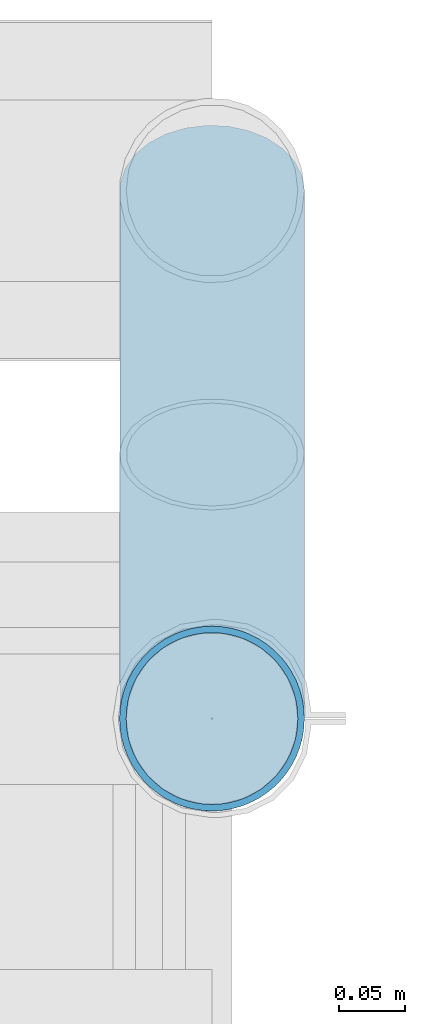
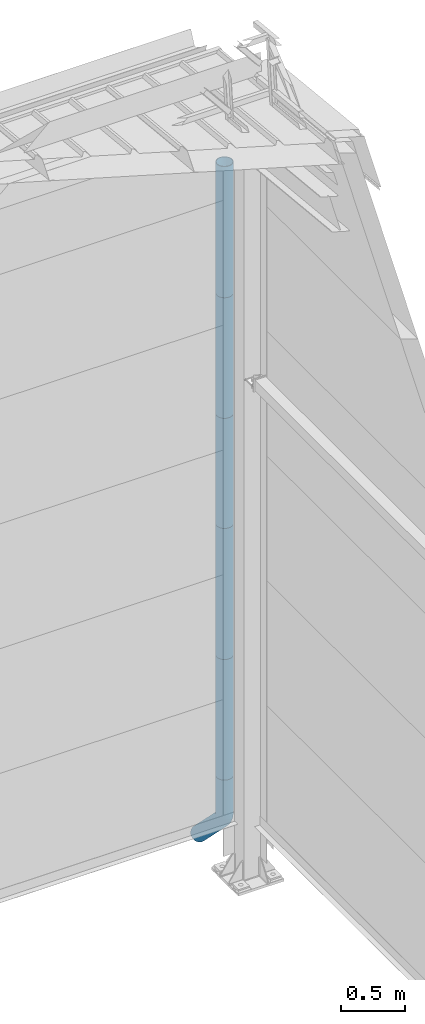
# One storey, part 81 of 709: 6 beams, 6 elements without a shape of their own.
"""IFC4 building model written with IfcOpenShell, lengths in millimetres."""

from ifc_helpers import new_model, entity, si_unit, direction, frame, origin_with_axes, place, context, subcontext, project, spatial, line, indexed_curve, outline, extrude, material, element, aggregate, save


model = new_model("IFC4")

# Units and contexts
model_context = context("Model", 3, precision=0.2, world=origin_with_axes(), true_north=direction((0.0, 1.0)))
body_context = subcontext(model_context, "Body", "Model", "MODEL_VIEW")
ifc_project = project(units=[si_unit("LENGTHUNIT", "METRE", prefix="MILLI"), si_unit("AREAUNIT", "SQUARE_METRE"), si_unit("VOLUMEUNIT", "CUBIC_METRE"), si_unit("MASSUNIT", "GRAM", prefix="KILO"), si_unit("TIMEUNIT", "SECOND"), si_unit("PLANEANGLEUNIT", "RADIAN"), si_unit("SOLIDANGLEUNIT", "STERADIAN"), si_unit("THERMODYNAMICTEMPERATUREUNIT", "DEGREE_CELSIUS"), si_unit("LUMINOUSINTENSITYUNIT", "LUMEN")], contexts=[model_context])

# Site, building, storey
site_placement = place(None, origin_with_axes())
site = spatial("IfcSite", under=ifc_project, at=site_placement, CompositionType="ELEMENT")
building_placement = place(site_placement, origin_with_axes())
building = spatial("IfcBuilding", under=site, at=building_placement, Name="Undefined", CompositionType="ELEMENT")
storey_placement = place(building_placement, origin_with_axes())
storey = spatial("IfcBuildingStorey", under=building, at=storey_placement, Name="Undefined", CompositionType="ELEMENT", Elevation=0.0)

# Assembly, beam
assembly_1_placement = place(storey_placement, frame((50000.0, 22420.0, 6276.92297), z_axis=(0.0, -1.0, 0.0), x_axis=(0.0, 0.0, -1.0)))
assembly_1 = element("IfcElementAssembly", 1, at=assembly_1_placement, inside=storey)
ifc_material = material(Name="Steel_Undefined", Category="STEEL")
beam_1_placement = place(assembly_1_placement, origin_with_axes())
beam_1 = element("IfcBeam", 2, at=beam_1_placement, material=ifc_material, ObjectType="614", context=body_context, shape_type="SolidModel", body=[
    extrude(outline(indexed_curve([(70.0, 0.0), (69.61653, 7.31699), (68.47033, 14.55382), (66.57396, 21.63119), (63.94818, 28.47157), (60.62178, 35.0), (56.63119, 41.14497), (52.02014, 46.83914), (46.83914, 52.02014), (41.14497, 56.63119), (35.0, 60.62178), (28.47157, 63.94818), (21.63119, 66.57396), (14.55382, 68.47033), (7.31699, 69.61653), (0.0, 70.0), (-7.31699, 69.61653), (-14.55382, 68.47033), (-21.63119, 66.57396), (-28.47157, 63.94818), (-35.0, 60.62178), (-41.14497, 56.63119), (-46.83914, 52.02014), (-52.02014, 46.83914), (-56.63119, 41.14497), (-60.62178, 35.0), (-63.94818, 28.47157), (-66.57396, 21.63119), (-68.47033, 14.55382), (-69.61653, 7.31699), (-70.0, 0.0), (-69.61653, -7.31699), (-68.47033, -14.55382), (-66.57396, -21.63119), (-63.94818, -28.47157), (-60.62178, -35.0), (-56.63119, -41.14497), (-52.02014, -46.83914), (-46.83914, -52.02014), (-41.14497, -56.63119), (-35.0, -60.62178), (-28.47157, -63.94818), (-21.63119, -66.57396), (-14.55382, -68.47033), (-7.31699, -69.61653), (0.0, -70.0), (7.31699, -69.61653), (14.55382, -68.47033), (21.63119, -66.57396), (28.47157, -63.94818), (35.0, -60.62178), (41.14497, -56.63119), (46.83914, -52.02014), (52.02014, -46.83914), (56.63119, -41.14497), (60.62178, -35.0), (63.94818, -28.47157), (66.57396, -21.63119), (68.47033, -14.55382), (69.61653, -7.31699)], segments=[line(1, 2, 3, 4, 5, 6, 7, 8, 9, 10, 11, 12, 13, 14, 15, 16, 17, 18, 19, 20, 21, 22, 23, 24, 25, 26, 27, 28, 29, 30, 31, 32, 33, 34, 35, 36, 37, 38, 39, 40, 41, 42, 43, 44, 45, 46, 47, 48, 49, 50, 51, 52, 53, 54, 55, 56, 57, 58, 59, 60, 1)]), holes=[indexed_curve([(65.0, 0.0), (64.64392, -6.79435), (63.57959, -13.51426), (61.81867, -20.0861), (59.38045, -26.43788), (56.29165, -32.5), (52.5861, -38.20604), (48.30441, -43.49349), (43.49349, -48.30441), (38.20604, -52.5861), (32.5, -56.29165), (26.43788, -59.38045), (20.0861, -61.81867), (13.51426, -63.57959), (6.79435, -64.64392), (0.0, -65.0), (-6.79435, -64.64392), (-13.51426, -63.57959), (-20.0861, -61.81867), (-26.43788, -59.38045), (-32.5, -56.29165), (-38.20604, -52.5861), (-43.49349, -48.30441), (-48.30441, -43.49349), (-52.5861, -38.20604), (-56.29165, -32.5), (-59.38045, -26.43788), (-61.81867, -20.0861), (-63.57959, -13.51426), (-64.64392, -6.79435), (-65.0, 0.0), (-64.64392, 6.79435), (-63.57959, 13.51426), (-61.81867, 20.0861), (-59.38045, 26.43788), (-56.29165, 32.5), (-52.5861, 38.20604), (-48.30441, 43.49349), (-43.49349, 48.30441), (-38.20604, 52.5861), (-32.5, 56.29165), (-26.43788, 59.38045), (-20.0861, 61.81867), (-13.51426, 63.57959), (-6.79435, 64.64392), (0.0, 65.0), (6.79435, 64.64392), (13.51426, 63.57959), (20.0861, 61.81867), (26.43788, 59.38045), (32.5, 56.29165), (38.20604, 52.5861), (43.49349, 48.30441), (48.30441, 43.49349), (52.5861, 38.20604), (56.29165, 32.5), (59.38045, 26.43788), (61.81867, 20.0861), (63.57959, 13.51426), (64.64392, 6.79435)], segments=[line(1, 2, 3, 4, 5, 6, 7, 8, 9, 10, 11, 12, 13, 14, 15, 16, 17, 18, 19, 20, 21, 22, 23, 24, 25, 26, 27, 28, 29, 30, 31, 32, 33, 34, 35, 36, 37, 38, 39, 40, 41, 42, 43, 44, 45, 46, 47, 48, 49, 50, 51, 52, 53, 54, 55, 56, 57, 58, 59, 60, 1)])]), frame((0.0, 0.0, 0.0), z_axis=(-1.0, 0.0, 0.0), x_axis=(0.0, 0.0, 1.0)), (0.0, 0.0, -1.0), 1250.0),
])
aggregate(assembly_1, [beam_1])

assembly_2_placement = place(storey_placement, frame((50000.0, 22420.0, 5126.92297), z_axis=(0.0, -1.0, 0.0), x_axis=(0.0, 0.0, -1.0)))
assembly_2 = element("IfcElementAssembly", 3, at=assembly_2_placement, inside=storey)
beam_2_placement = place(assembly_2_placement, origin_with_axes())
beam_2 = element("IfcBeam", 4, at=beam_2_placement, material=ifc_material, ObjectType="614", context=body_context, shape_type="SolidModel", body=[
    extrude(outline(indexed_curve([(70.0, 0.0), (69.61653, 7.31699), (68.47033, 14.55382), (66.57396, 21.63119), (63.94818, 28.47157), (60.62178, 35.0), (56.63119, 41.14497), (52.02014, 46.83914), (46.83914, 52.02014), (41.14497, 56.63119), (35.0, 60.62178), (28.47157, 63.94818), (21.63119, 66.57396), (14.55382, 68.47033), (7.31699, 69.61653), (0.0, 70.0), (-7.31699, 69.61653), (-14.55382, 68.47033), (-21.63119, 66.57396), (-28.47157, 63.94818), (-35.0, 60.62178), (-41.14497, 56.63119), (-46.83914, 52.02014), (-52.02014, 46.83914), (-56.63119, 41.14497), (-60.62178, 35.0), (-63.94818, 28.47157), (-66.57396, 21.63119), (-68.47033, 14.55382), (-69.61653, 7.31699), (-70.0, 0.0), (-69.61653, -7.31699), (-68.47033, -14.55382), (-66.57396, -21.63119), (-63.94818, -28.47157), (-60.62178, -35.0), (-56.63119, -41.14497), (-52.02014, -46.83914), (-46.83914, -52.02014), (-41.14497, -56.63119), (-35.0, -60.62178), (-28.47157, -63.94818), (-21.63119, -66.57396), (-14.55382, -68.47033), (-7.31699, -69.61653), (0.0, -70.0), (7.31699, -69.61653), (14.55382, -68.47033), (21.63119, -66.57396), (28.47157, -63.94818), (35.0, -60.62178), (41.14497, -56.63119), (46.83914, -52.02014), (52.02014, -46.83914), (56.63119, -41.14497), (60.62178, -35.0), (63.94818, -28.47157), (66.57396, -21.63119), (68.47033, -14.55382), (69.61653, -7.31699)], segments=[line(1, 2, 3, 4, 5, 6, 7, 8, 9, 10, 11, 12, 13, 14, 15, 16, 17, 18, 19, 20, 21, 22, 23, 24, 25, 26, 27, 28, 29, 30, 31, 32, 33, 34, 35, 36, 37, 38, 39, 40, 41, 42, 43, 44, 45, 46, 47, 48, 49, 50, 51, 52, 53, 54, 55, 56, 57, 58, 59, 60, 1)]), holes=[indexed_curve([(65.0, 0.0), (64.64392, -6.79435), (63.57959, -13.51426), (61.81867, -20.0861), (59.38045, -26.43788), (56.29165, -32.5), (52.5861, -38.20604), (48.30441, -43.49349), (43.49349, -48.30441), (38.20604, -52.5861), (32.5, -56.29165), (26.43788, -59.38045), (20.0861, -61.81867), (13.51426, -63.57959), (6.79435, -64.64392), (0.0, -65.0), (-6.79435, -64.64392), (-13.51426, -63.57959), (-20.0861, -61.81867), (-26.43788, -59.38045), (-32.5, -56.29165), (-38.20604, -52.5861), (-43.49349, -48.30441), (-48.30441, -43.49349), (-52.5861, -38.20604), (-56.29165, -32.5), (-59.38045, -26.43788), (-61.81867, -20.0861), (-63.57959, -13.51426), (-64.64392, -6.79435), (-65.0, 0.0), (-64.64392, 6.79435), (-63.57959, 13.51426), (-61.81867, 20.0861), (-59.38045, 26.43788), (-56.29165, 32.5), (-52.5861, 38.20604), (-48.30441, 43.49349), (-43.49349, 48.30441), (-38.20604, 52.5861), (-32.5, 56.29165), (-26.43788, 59.38045), (-20.0861, 61.81867), (-13.51426, 63.57959), (-6.79435, 64.64392), (0.0, 65.0), (6.79435, 64.64392), (13.51426, 63.57959), (20.0861, 61.81867), (26.43788, 59.38045), (32.5, 56.29165), (38.20604, 52.5861), (43.49349, 48.30441), (48.30441, 43.49349), (52.5861, 38.20604), (56.29165, 32.5), (59.38045, 26.43788), (61.81867, 20.0861), (63.57959, 13.51426), (64.64392, 6.79435)], segments=[line(1, 2, 3, 4, 5, 6, 7, 8, 9, 10, 11, 12, 13, 14, 15, 16, 17, 18, 19, 20, 21, 22, 23, 24, 25, 26, 27, 28, 29, 30, 31, 32, 33, 34, 35, 36, 37, 38, 39, 40, 41, 42, 43, 44, 45, 46, 47, 48, 49, 50, 51, 52, 53, 54, 55, 56, 57, 58, 59, 60, 1)])]), frame((0.0, 0.0, 0.0), z_axis=(-1.0, 0.0, 0.0), x_axis=(0.0, 0.0, 1.0)), (0.0, 0.0, -1.0), 1250.0),
])
aggregate(assembly_2, [beam_2])

assembly_3_placement = place(storey_placement, frame((50000.0, 22420.0, 3976.92297), z_axis=(0.0, -1.0, 0.0), x_axis=(0.0, 0.0, -1.0)))
assembly_3 = element("IfcElementAssembly", 5, at=assembly_3_placement, inside=storey)
beam_3_placement = place(assembly_3_placement, origin_with_axes())
beam_3 = element("IfcBeam", 6, at=beam_3_placement, material=ifc_material, ObjectType="614", context=body_context, shape_type="SolidModel", body=[
    extrude(outline(indexed_curve([(70.0, 0.0), (69.61653, 7.31699), (68.47033, 14.55382), (66.57396, 21.63119), (63.94818, 28.47157), (60.62178, 35.0), (56.63119, 41.14497), (52.02014, 46.83914), (46.83914, 52.02014), (41.14497, 56.63119), (35.0, 60.62178), (28.47157, 63.94818), (21.63119, 66.57396), (14.55382, 68.47033), (7.31699, 69.61653), (0.0, 70.0), (-7.31699, 69.61653), (-14.55382, 68.47033), (-21.63119, 66.57396), (-28.47157, 63.94818), (-35.0, 60.62178), (-41.14497, 56.63119), (-46.83914, 52.02014), (-52.02014, 46.83914), (-56.63119, 41.14497), (-60.62178, 35.0), (-63.94818, 28.47157), (-66.57396, 21.63119), (-68.47033, 14.55382), (-69.61653, 7.31699), (-70.0, 0.0), (-69.61653, -7.31699), (-68.47033, -14.55382), (-66.57396, -21.63119), (-63.94818, -28.47157), (-60.62178, -35.0), (-56.63119, -41.14497), (-52.02014, -46.83914), (-46.83914, -52.02014), (-41.14497, -56.63119), (-35.0, -60.62178), (-28.47157, -63.94818), (-21.63119, -66.57396), (-14.55382, -68.47033), (-7.31699, -69.61653), (0.0, -70.0), (7.31699, -69.61653), (14.55382, -68.47033), (21.63119, -66.57396), (28.47157, -63.94818), (35.0, -60.62178), (41.14497, -56.63119), (46.83914, -52.02014), (52.02014, -46.83914), (56.63119, -41.14497), (60.62178, -35.0), (63.94818, -28.47157), (66.57396, -21.63119), (68.47033, -14.55382), (69.61653, -7.31699)], segments=[line(1, 2, 3, 4, 5, 6, 7, 8, 9, 10, 11, 12, 13, 14, 15, 16, 17, 18, 19, 20, 21, 22, 23, 24, 25, 26, 27, 28, 29, 30, 31, 32, 33, 34, 35, 36, 37, 38, 39, 40, 41, 42, 43, 44, 45, 46, 47, 48, 49, 50, 51, 52, 53, 54, 55, 56, 57, 58, 59, 60, 1)]), holes=[indexed_curve([(65.0, 0.0), (64.64392, -6.79435), (63.57959, -13.51426), (61.81867, -20.0861), (59.38045, -26.43788), (56.29165, -32.5), (52.5861, -38.20604), (48.30441, -43.49349), (43.49349, -48.30441), (38.20604, -52.5861), (32.5, -56.29165), (26.43788, -59.38045), (20.0861, -61.81867), (13.51426, -63.57959), (6.79435, -64.64392), (0.0, -65.0), (-6.79435, -64.64392), (-13.51426, -63.57959), (-20.0861, -61.81867), (-26.43788, -59.38045), (-32.5, -56.29165), (-38.20604, -52.5861), (-43.49349, -48.30441), (-48.30441, -43.49349), (-52.5861, -38.20604), (-56.29165, -32.5), (-59.38045, -26.43788), (-61.81867, -20.0861), (-63.57959, -13.51426), (-64.64392, -6.79435), (-65.0, 0.0), (-64.64392, 6.79435), (-63.57959, 13.51426), (-61.81867, 20.0861), (-59.38045, 26.43788), (-56.29165, 32.5), (-52.5861, 38.20604), (-48.30441, 43.49349), (-43.49349, 48.30441), (-38.20604, 52.5861), (-32.5, 56.29165), (-26.43788, 59.38045), (-20.0861, 61.81867), (-13.51426, 63.57959), (-6.79435, 64.64392), (0.0, 65.0), (6.79435, 64.64392), (13.51426, 63.57959), (20.0861, 61.81867), (26.43788, 59.38045), (32.5, 56.29165), (38.20604, 52.5861), (43.49349, 48.30441), (48.30441, 43.49349), (52.5861, 38.20604), (56.29165, 32.5), (59.38045, 26.43788), (61.81867, 20.0861), (63.57959, 13.51426), (64.64392, 6.79435)], segments=[line(1, 2, 3, 4, 5, 6, 7, 8, 9, 10, 11, 12, 13, 14, 15, 16, 17, 18, 19, 20, 21, 22, 23, 24, 25, 26, 27, 28, 29, 30, 31, 32, 33, 34, 35, 36, 37, 38, 39, 40, 41, 42, 43, 44, 45, 46, 47, 48, 49, 50, 51, 52, 53, 54, 55, 56, 57, 58, 59, 60, 1)])]), frame((0.0, 0.0, 0.0), z_axis=(-1.0, 0.0, 0.0), x_axis=(0.0, 0.0, 1.0)), (0.0, 0.0, -1.0), 1250.0),
])
aggregate(assembly_3, [beam_3])

assembly_4_placement = place(storey_placement, frame((50000.0, 22420.0, 2826.92297), z_axis=(0.0, -1.0, 0.0), x_axis=(0.0, 0.0, -1.0)))
assembly_4 = element("IfcElementAssembly", 7, at=assembly_4_placement, inside=storey)
beam_4_placement = place(assembly_4_placement, origin_with_axes())
beam_4 = element("IfcBeam", 8, at=beam_4_placement, material=ifc_material, ObjectType="614", context=body_context, shape_type="SolidModel", body=[
    extrude(outline(indexed_curve([(70.0, 0.0), (69.61653, 7.31699), (68.47033, 14.55382), (66.57396, 21.63119), (63.94818, 28.47157), (60.62178, 35.0), (56.63119, 41.14497), (52.02014, 46.83914), (46.83914, 52.02014), (41.14497, 56.63119), (35.0, 60.62178), (28.47157, 63.94818), (21.63119, 66.57396), (14.55382, 68.47033), (7.31699, 69.61653), (0.0, 70.0), (-7.31699, 69.61653), (-14.55382, 68.47033), (-21.63119, 66.57396), (-28.47157, 63.94818), (-35.0, 60.62178), (-41.14497, 56.63119), (-46.83914, 52.02014), (-52.02014, 46.83914), (-56.63119, 41.14497), (-60.62178, 35.0), (-63.94818, 28.47157), (-66.57396, 21.63119), (-68.47033, 14.55382), (-69.61653, 7.31699), (-70.0, 0.0), (-69.61653, -7.31699), (-68.47033, -14.55382), (-66.57396, -21.63119), (-63.94818, -28.47157), (-60.62178, -35.0), (-56.63119, -41.14497), (-52.02014, -46.83914), (-46.83914, -52.02014), (-41.14497, -56.63119), (-35.0, -60.62178), (-28.47157, -63.94818), (-21.63119, -66.57396), (-14.55382, -68.47033), (-7.31699, -69.61653), (0.0, -70.0), (7.31699, -69.61653), (14.55382, -68.47033), (21.63119, -66.57396), (28.47157, -63.94818), (35.0, -60.62178), (41.14497, -56.63119), (46.83914, -52.02014), (52.02014, -46.83914), (56.63119, -41.14497), (60.62178, -35.0), (63.94818, -28.47157), (66.57396, -21.63119), (68.47033, -14.55382), (69.61653, -7.31699)], segments=[line(1, 2, 3, 4, 5, 6, 7, 8, 9, 10, 11, 12, 13, 14, 15, 16, 17, 18, 19, 20, 21, 22, 23, 24, 25, 26, 27, 28, 29, 30, 31, 32, 33, 34, 35, 36, 37, 38, 39, 40, 41, 42, 43, 44, 45, 46, 47, 48, 49, 50, 51, 52, 53, 54, 55, 56, 57, 58, 59, 60, 1)]), holes=[indexed_curve([(65.0, 0.0), (64.64392, -6.79435), (63.57959, -13.51426), (61.81867, -20.0861), (59.38045, -26.43788), (56.29165, -32.5), (52.5861, -38.20604), (48.30441, -43.49349), (43.49349, -48.30441), (38.20604, -52.5861), (32.5, -56.29165), (26.43788, -59.38045), (20.0861, -61.81867), (13.51426, -63.57959), (6.79435, -64.64392), (0.0, -65.0), (-6.79435, -64.64392), (-13.51426, -63.57959), (-20.0861, -61.81867), (-26.43788, -59.38045), (-32.5, -56.29165), (-38.20604, -52.5861), (-43.49349, -48.30441), (-48.30441, -43.49349), (-52.5861, -38.20604), (-56.29165, -32.5), (-59.38045, -26.43788), (-61.81867, -20.0861), (-63.57959, -13.51426), (-64.64392, -6.79435), (-65.0, 0.0), (-64.64392, 6.79435), (-63.57959, 13.51426), (-61.81867, 20.0861), (-59.38045, 26.43788), (-56.29165, 32.5), (-52.5861, 38.20604), (-48.30441, 43.49349), (-43.49349, 48.30441), (-38.20604, 52.5861), (-32.5, 56.29165), (-26.43788, 59.38045), (-20.0861, 61.81867), (-13.51426, 63.57959), (-6.79435, 64.64392), (0.0, 65.0), (6.79435, 64.64392), (13.51426, 63.57959), (20.0861, 61.81867), (26.43788, 59.38045), (32.5, 56.29165), (38.20604, 52.5861), (43.49349, 48.30441), (48.30441, 43.49349), (52.5861, 38.20604), (56.29165, 32.5), (59.38045, 26.43788), (61.81867, 20.0861), (63.57959, 13.51426), (64.64392, 6.79435)], segments=[line(1, 2, 3, 4, 5, 6, 7, 8, 9, 10, 11, 12, 13, 14, 15, 16, 17, 18, 19, 20, 21, 22, 23, 24, 25, 26, 27, 28, 29, 30, 31, 32, 33, 34, 35, 36, 37, 38, 39, 40, 41, 42, 43, 44, 45, 46, 47, 48, 49, 50, 51, 52, 53, 54, 55, 56, 57, 58, 59, 60, 1)])]), frame((0.0, 0.0, 0.0), z_axis=(-1.0, 0.0, 0.0), x_axis=(0.0, 0.0, 1.0)), (0.0, 0.0, -1.0), 1250.0),
])
aggregate(assembly_4, [beam_4])

assembly_5_placement = place(storey_placement, frame((50000.0, 22420.0, 1676.92297), z_axis=(0.0, -1.0, 0.0), x_axis=(0.0, 0.0, -1.0)))
assembly_5 = element("IfcElementAssembly", 9, at=assembly_5_placement, inside=storey)
beam_5_placement = place(assembly_5_placement, origin_with_axes())
beam_5 = element("IfcBeam", 10, at=beam_5_placement, material=ifc_material, ObjectType="614", context=body_context, shape_type="SolidModel", body=[
    extrude(outline(indexed_curve([(70.0, 0.0), (69.61653, 7.31699), (68.47033, 14.55382), (66.57396, 21.63119), (63.94818, 28.47157), (60.62178, 35.0), (56.63119, 41.14497), (52.02014, 46.83914), (46.83914, 52.02014), (41.14497, 56.63119), (35.0, 60.62178), (28.47157, 63.94818), (21.63119, 66.57396), (14.55382, 68.47033), (7.31699, 69.61653), (0.0, 70.0), (-7.31699, 69.61653), (-14.55382, 68.47033), (-21.63119, 66.57396), (-28.47157, 63.94818), (-35.0, 60.62178), (-41.14497, 56.63119), (-46.83914, 52.02014), (-52.02014, 46.83914), (-56.63119, 41.14497), (-60.62178, 35.0), (-63.94818, 28.47157), (-66.57396, 21.63119), (-68.47033, 14.55382), (-69.61653, 7.31699), (-70.0, 0.0), (-69.61653, -7.31699), (-68.47033, -14.55382), (-66.57396, -21.63119), (-63.94818, -28.47157), (-60.62178, -35.0), (-56.63119, -41.14497), (-52.02014, -46.83914), (-46.83914, -52.02014), (-41.14497, -56.63119), (-35.0, -60.62178), (-28.47157, -63.94818), (-21.63119, -66.57396), (-14.55382, -68.47033), (-7.31699, -69.61653), (0.0, -70.0), (7.31699, -69.61653), (14.55382, -68.47033), (21.63119, -66.57396), (28.47157, -63.94818), (35.0, -60.62178), (41.14497, -56.63119), (46.83914, -52.02014), (52.02014, -46.83914), (56.63119, -41.14497), (60.62178, -35.0), (63.94818, -28.47157), (66.57396, -21.63119), (68.47033, -14.55382), (69.61653, -7.31699)], segments=[line(1, 2, 3, 4, 5, 6, 7, 8, 9, 10, 11, 12, 13, 14, 15, 16, 17, 18, 19, 20, 21, 22, 23, 24, 25, 26, 27, 28, 29, 30, 31, 32, 33, 34, 35, 36, 37, 38, 39, 40, 41, 42, 43, 44, 45, 46, 47, 48, 49, 50, 51, 52, 53, 54, 55, 56, 57, 58, 59, 60, 1)]), holes=[indexed_curve([(65.0, 0.0), (64.64392, -6.79435), (63.57959, -13.51426), (61.81867, -20.0861), (59.38045, -26.43788), (56.29165, -32.5), (52.5861, -38.20604), (48.30441, -43.49349), (43.49349, -48.30441), (38.20604, -52.5861), (32.5, -56.29165), (26.43788, -59.38045), (20.0861, -61.81867), (13.51426, -63.57959), (6.79435, -64.64392), (0.0, -65.0), (-6.79435, -64.64392), (-13.51426, -63.57959), (-20.0861, -61.81867), (-26.43788, -59.38045), (-32.5, -56.29165), (-38.20604, -52.5861), (-43.49349, -48.30441), (-48.30441, -43.49349), (-52.5861, -38.20604), (-56.29165, -32.5), (-59.38045, -26.43788), (-61.81867, -20.0861), (-63.57959, -13.51426), (-64.64392, -6.79435), (-65.0, 0.0), (-64.64392, 6.79435), (-63.57959, 13.51426), (-61.81867, 20.0861), (-59.38045, 26.43788), (-56.29165, 32.5), (-52.5861, 38.20604), (-48.30441, 43.49349), (-43.49349, 48.30441), (-38.20604, 52.5861), (-32.5, 56.29165), (-26.43788, 59.38045), (-20.0861, 61.81867), (-13.51426, 63.57959), (-6.79435, 64.64392), (0.0, 65.0), (6.79435, 64.64392), (13.51426, 63.57959), (20.0861, 61.81867), (26.43788, 59.38045), (32.5, 56.29165), (38.20604, 52.5861), (43.49349, 48.30441), (48.30441, 43.49349), (52.5861, 38.20604), (56.29165, 32.5), (59.38045, 26.43788), (61.81867, 20.0861), (63.57959, 13.51426), (64.64392, 6.79435)], segments=[line(1, 2, 3, 4, 5, 6, 7, 8, 9, 10, 11, 12, 13, 14, 15, 16, 17, 18, 19, 20, 21, 22, 23, 24, 25, 26, 27, 28, 29, 30, 31, 32, 33, 34, 35, 36, 37, 38, 39, 40, 41, 42, 43, 44, 45, 46, 47, 48, 49, 50, 51, 52, 53, 54, 55, 56, 57, 58, 59, 60, 1)])]), frame((0.0, 0.0, 0.0), z_axis=(-1.0, 0.0, 0.0), x_axis=(0.0, 0.0, 1.0)), (0.0, 0.0, -1.0), 1250.0),
])
aggregate(assembly_5, [beam_5])

assembly_6_placement = place(storey_placement, frame((50000.0, 22420.0, 526.92297), z_axis=(1.0, 0.0, 0.0), x_axis=(0.0, 0.0, -1.0)))
assembly_6 = element("IfcElementAssembly", 11, at=assembly_6_placement, inside=storey)
beam_6_placement = place(assembly_6_placement, origin_with_axes())
beam_6 = element("IfcBeam", 12, at=beam_6_placement, material=ifc_material, ObjectType="617", context=body_context, shape_type="SolidModel", body=[
    entity("IfcSweptDiskSolid", entity("IfcIndexedPolyCurve", entity("IfcCartesianPointList3D", [[0.0, 0.0, 0.0], [448.2233, 0.0, 0.0], [496.05873, 9.51506, 0.0], [536.61165, 36.61165, 0.0], [900.0, 400.0, 0.0]]), [entity("IfcLineIndex", [1, 2]), entity("IfcArcIndex", [2, 3, 4]), entity("IfcLineIndex", [4, 5])]), 70.0, 65.0),
])
aggregate(assembly_6, [beam_6])

save(model, "model.ifc")
